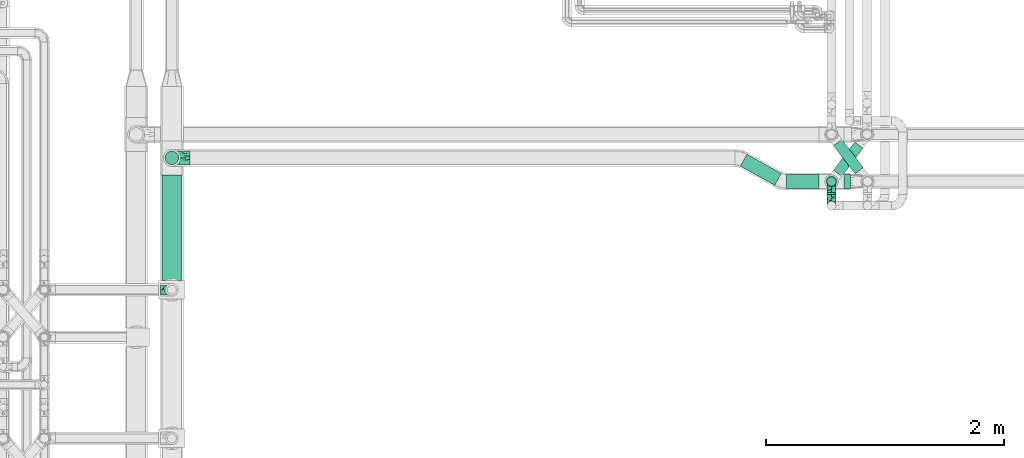
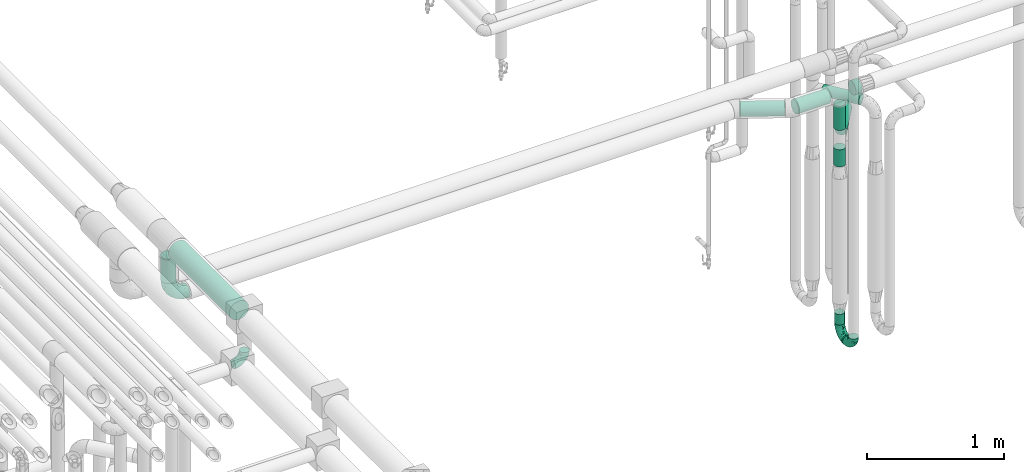
# One storey, part 628 of 827: 11 flow segments, 4 flow fittings.
"""IFC2X3 building model written with IfcOpenShell, lengths in millimetres."""

from ifc_helpers import new_model, entity, si_unit, converted_unit, derived_unit, direction, frame, origin, origin_2d_with_axis, place, context, subcontext, project, spatial, circle, extrude, faceted_brep, source, transform, mapped, material, type_object, type_shapes, element, save


model = new_model("IFC2X3")

# Units and contexts
model_context = context("Model", 3, precision=0.01, world=origin(), true_north=direction((6.12303176911189e-17, 1.0)))
body_context = subcontext(model_context, "Body", "Model", "MODEL_VIEW")
ifc_project = project(units=[si_unit("LENGTHUNIT", "METRE", prefix="MILLI"), si_unit("AREAUNIT", "SQUARE_METRE"), si_unit("VOLUMEUNIT", "CUBIC_METRE"), converted_unit("PLANEANGLEUNIT", "DEGREE", entity("IfcRatioMeasure", 0.0174532925199433), si_unit("PLANEANGLEUNIT", "RADIAN"), dimensions=[0, 0, 0, 0, 0, 0, 0]), si_unit("MASSUNIT", "GRAM", prefix="KILO"), derived_unit("MASSDENSITYUNIT", [(si_unit("MASSUNIT", "GRAM", prefix="KILO"), 1), (si_unit("LENGTHUNIT", "METRE"), -3)]), derived_unit("MOMENTOFINERTIAUNIT", [(si_unit("LENGTHUNIT", "METRE"), 4)]), si_unit("TIMEUNIT", "SECOND"), si_unit("FREQUENCYUNIT", "HERTZ"), si_unit("THERMODYNAMICTEMPERATUREUNIT", "DEGREE_CELSIUS"), derived_unit("THERMALTRANSMITTANCEUNIT", [(si_unit("MASSUNIT", "GRAM", prefix="KILO"), 1), (si_unit("THERMODYNAMICTEMPERATUREUNIT", "KELVIN"), -1), (si_unit("TIMEUNIT", "SECOND"), -3)]), derived_unit("VOLUMETRICFLOWRATEUNIT", [(si_unit("LENGTHUNIT", "METRE"), 3), (si_unit("TIMEUNIT", "SECOND"), -1)]), derived_unit("MASSFLOWRATEUNIT", [(si_unit("MASSUNIT", "GRAM", prefix="KILO"), 1), (si_unit("TIMEUNIT", "SECOND"), -1)]), derived_unit("ROTATIONALFREQUENCYUNIT", [(si_unit("TIMEUNIT", "SECOND"), -1)]), si_unit("ELECTRICCURRENTUNIT", "AMPERE"), si_unit("ELECTRICVOLTAGEUNIT", "VOLT"), si_unit("POWERUNIT", "WATT"), si_unit("FORCEUNIT", "NEWTON", prefix="KILO"), si_unit("ILLUMINANCEUNIT", "LUX"), si_unit("LUMINOUSFLUXUNIT", "LUMEN"), si_unit("LUMINOUSINTENSITYUNIT", "CANDELA"), derived_unit("USERDEFINED", [(si_unit("MASSUNIT", "GRAM", prefix="KILO"), -1), (si_unit("LENGTHUNIT", "METRE"), -2), (si_unit("TIMEUNIT", "SECOND"), 3), (si_unit("LUMINOUSFLUXUNIT", "LUMEN"), 1)]), derived_unit("LINEARVELOCITYUNIT", [(si_unit("LENGTHUNIT", "METRE"), 1), (si_unit("TIMEUNIT", "SECOND"), -1)]), si_unit("PRESSUREUNIT", "PASCAL"), derived_unit("USERDEFINED", [(si_unit("LENGTHUNIT", "METRE"), -2), (si_unit("MASSUNIT", "GRAM", prefix="KILO"), 1), (si_unit("TIMEUNIT", "SECOND"), -2)]), derived_unit("LINEARFORCEUNIT", [(si_unit("MASSUNIT", "GRAM", prefix="KILO"), 1), (si_unit("LENGTHUNIT", "METRE"), 1), (si_unit("TIMEUNIT", "SECOND"), -2), (si_unit("LENGTHUNIT", "METRE"), -1)]), derived_unit("PLANARFORCEUNIT", [(si_unit("MASSUNIT", "GRAM", prefix="KILO"), 1), (si_unit("LENGTHUNIT", "METRE"), 1), (si_unit("TIMEUNIT", "SECOND"), -2), (si_unit("LENGTHUNIT", "METRE"), -2)])], contexts=[model_context])

# Site, building, storey
site_placement = place(None, origin())
site = spatial("IfcSite", under=ifc_project, at=site_placement, CompositionType="ELEMENT")
building_placement = place(site_placement, origin())
building = spatial("IfcBuilding", under=site, at=building_placement, CompositionType="ELEMENT")
storey_placement = place(building_placement, frame((0.0, 0.0, 28200.0)))
storey = spatial("IfcBuildingStorey", under=building, at=storey_placement, Name="08", CompositionType="ELEMENT", Elevation=28200.0)

# Flow segments
pipe_segment_type = type_object("IfcPipeSegmentType", PredefinedType="NOTDEFINED")
flow_segment_1_placement = place(storey_placement, frame((43217.53, 13831.58, 2441.4)))
element("IfcFlowSegment", 1, at=flow_segment_1_placement, inside=storey, type_object=pipe_segment_type, context=body_context, shape_type="SweptSolid", body=[
    extrude(circle(Radius=57.0, at=origin_2d_with_axis()), frame((0.0, 58.6, 58.6), z_axis=(1.0, 0.0, 0.0), x_axis=(0.0, 1.0, 0.0)), (0.0, 0.0, 1.0), 272.991412851327),
])
flow_segment_2_placement = place(storey_placement, frame((42827.16, 13856.6, 2441.4)))
element("IfcFlowSegment", 2, at=flow_segment_2_placement, inside=storey, type_object=pipe_segment_type, context=body_context, shape_type="SweptSolid", body=[
    extrude(circle(Radius=57.0, at=origin_2d_with_axis()), frame((319.01, 51.37, 58.6), z_axis=(-0.873180609526805, 0.48739678204354, 0.0), x_axis=(0.48739678204354, 0.873180609526805, 0.0)), (0.0, 0.0, 1.0), 331.703383330537),
])
flow_segment_3_placement = place(storey_placement, frame((43556.18, 13781.84, 310.65)))
element("IfcFlowSegment", 3, at=flow_segment_3_placement, inside=storey, type_object=pipe_segment_type, context=body_context, shape_type="SweptSolid", body=[
    extrude(circle(Radius=37.75, at=origin_2d_with_axis()), frame((39.35, 0.0, 39.35), z_axis=(0.0, 1.0, 0.0), x_axis=(1.0, 0.0, 0.0)), (0.0, 0.0, 1.0), 13.3318534116117),
])
flow_segment_4_placement = place(storey_placement, frame((43556.18, 13850.83, 445.0)))
element("IfcFlowSegment", 4, at=flow_segment_4_placement, inside=storey, type_object=pipe_segment_type, context=body_context, shape_type="SweptSolid", body=[
    extrude(circle(Radius=37.75, at=origin_2d_with_axis()), frame((39.35, 39.35, 0.0)), (0.0, 0.0, 1.0), 96.0215360887079),
])
flow_segment_5_placement = place(storey_placement, frame((43610.35, 13930.63, 2054.15)))
element("IfcFlowSegment", 5, at=flow_segment_5_placement, inside=storey, type_object=pipe_segment_type, context=body_context, shape_type="SweptSolid", body=[
    extrude(circle(Radius=44.25, at=origin_2d_with_axis()), frame((36.93, 28.23, 45.85), z_axis=(0.601815023152052, 0.79863551004729, 0.0), x_axis=(-0.79863551004729, 0.601815023152052, 0.0)), (0.0, 0.0, 1.0), 296.864462003746),
])
flow_segment_6_placement = place(storey_placement, frame((43549.68, 13844.33, 1860.0)))
element("IfcFlowSegment", 6, at=flow_segment_6_placement, inside=storey, type_object=pipe_segment_type, context=body_context, shape_type="SweptSolid", body=[
    extrude(circle(Radius=44.25, at=origin_2d_with_axis()), frame((45.85, 45.85, 0.0)), (0.0, 0.0, 1.0), 154.00000000003),
])
flow_segment_7_placement = place(storey_placement, frame((43549.68, 13844.33, 2186.0)))
element("IfcFlowSegment", 7, at=flow_segment_7_placement, inside=storey, type_object=pipe_segment_type, context=body_context, shape_type="SweptSolid", body=[
    extrude(circle(Radius=44.25, at=origin_2d_with_axis()), frame((45.85, 45.85, 0.0), z_axis=(0.0, 0.0, 1.0), x_axis=(-1.0, 0.0, 0.0)), (0.0, 0.0, 1.0), 215.999999999986),
])
flow_segment_8_placement = place(storey_placement, frame((43610.53, 13952.25, 2254.15)))
element("IfcFlowSegment", 8, at=flow_segment_8_placement, inside=storey, type_object=pipe_segment_type, context=body_context, shape_type="SweptSolid", body=[
    extrude(circle(Radius=44.25, at=origin_2d_with_axis()), frame((36.74, 266.05, 45.85), z_axis=(0.607471228521982, -0.794341681216587, 0.0), x_axis=(0.794341681216587, 0.607471228521982, 0.0)), (0.0, 0.0, 1.0), 299.088593690858),
])
flow_segment_9_placement = place(storey_placement, frame((37964.2, 13057.14, 2915.9)))
element("IfcFlowSegment", 9, at=flow_segment_9_placement, inside=storey, type_object=pipe_segment_type, context=body_context, shape_type="SweptSolid", body=[
    extrude(circle(Radius=82.5, at=origin_2d_with_axis()), frame((84.1, 0.0, 84.1), z_axis=(0.0, 1.0, 0.0), x_axis=(-1.0, 0.0, 0.0)), (0.0, 0.0, 1.0), 888.770675700639),
])
flow_segment_10_placement = place(storey_placement, frame((37989.7, 14030.32, 2652.0)))
element("IfcFlowSegment", 10, at=flow_segment_10_placement, inside=storey, type_object=pipe_segment_type, context=body_context, shape_type="SweptSolid", body=[
    extrude(circle(Radius=57.0, at=origin_2d_with_axis()), frame((58.6, 58.6, 0.0)), (0.0, 0.0, 1.0), 218.000000000007),
])
flow_segment_11_placement = place(storey_placement, frame((43700.53, 13831.58, 2441.4)))
element("IfcFlowSegment", 11, at=flow_segment_11_placement, inside=storey, type_object=pipe_segment_type, context=body_context, shape_type="SweptSolid", body=[
    extrude(circle(Radius=57.0, at=origin_2d_with_axis()), frame((0.0, 58.6, 58.6), z_axis=(1.0, 0.0, 0.0), x_axis=(0.0, 1.0, 0.0)), (0.0, 0.0, 1.0), 53.6562870233953),
])

# Flow fittings
ifc_material = material()
pipe_fitting_type_1 = type_object("IfcPipeFittingType", Name="ADSK_1", PredefinedType="NOTDEFINED", material=ifc_material)
shared_shape_1 = source(origin(), body_context, "Body", "Brep", [
    faceted_brep([(-95.0, 19.02, -32.95), (-95.0, 9.85, -36.75), (-95.0, 0.0, -38.05), (-95.0, -9.85, -36.75), (-95.0, -19.03, -32.95), (-95.0, -26.91, -26.91), (-95.0, -32.95, -19.03), (-95.0, -36.75, -9.85), (-95.0, -38.05, 0.0), (-95.0, -36.75, 9.85), (-95.0, -32.95, 19.02), (-95.0, -26.91, 26.91), (-95.0, -19.03, 32.95), (-95.0, -9.85, 36.75), (-95.0, 0.0, 38.05), (-95.0, 9.85, 36.75), (-95.0, 19.02, 32.95), (-95.0, 26.91, 26.91), (-95.0, 32.95, 19.02), (-95.0, 36.75, 9.85), (-95.0, 38.05, 0.0), (-95.0, 36.75, -9.85), (-95.0, 32.95, -19.03), (-95.0, 26.91, -26.91), (0.0, 95.0, -38.05), (-9.85, 95.0, -36.75), (-19.02, 95.0, -32.95), (-26.91, 95.0, -26.91), (-32.95, 95.0, -19.03), (-36.75, 95.0, -9.85), (-38.05, 95.0, 0.0), (-36.75, 95.0, 9.85), (-32.95, 95.0, 19.02), (-26.91, 95.0, 26.91), (-19.02, 95.0, 32.95), (-9.85, 95.0, 36.75), (0.0, 95.0, 38.05), (9.85, 95.0, 36.75), (19.03, 95.0, 32.95), (26.91, 95.0, 26.91), (32.95, 95.0, 19.02), (36.75, 95.0, 9.85), (38.05, 95.0, 0.0), (36.75, 95.0, -9.85), (32.95, 95.0, -19.03), (26.91, 95.0, -26.91), (19.03, 95.0, -32.95), (9.85, 95.0, -36.75), (-7.99, -4.96, 6.3), (-0.92, 0.92, 0.0), (4.62, 8.1, 8.01), (-76.19, -35.57, 0.0), (-64.32, -32.32, 12.43), (20.51, 62.45, 28.68), (-60.56, -33.52, 0.0), (-70.4, -13.47, 34.42), (-39.61, -5.88, 32.32), (-49.6, 2.07, 37.1), (-70.34, -28.81, 21.71), (14.64, 40.81, 26.5), (5.88, 39.61, 32.32), (3.59, 20.77, 25.31), (-40.45, 68.06, 16.75), (-62.45, -20.51, 28.68), (-44.52, -26.87, 0.0), (-28.47, -20.22, 0.0), (-26.43, -17.83, 8.75), (-76.1, 39.63, 10.76), (-72.74, 37.58, 18.19), (-60.35, 46.18, 14.61), (-13.4, 13.4, 32.12), (-20.77, -3.59, 25.31), (-14.66, 81.47, 35.56), (-6.22, 71.26, 37.92), (-57.5, 42.48, 22.79), (-15.0, 34.74, 37.7), (-27.1, 12.08, 36.05), (-9.2, 28.81, 35.63), (-79.98, 23.7, 30.95), (-73.68, -4.3, 37.48), (-30.74, 21.67, 37.97), (-62.36, 47.59, 6.79), (-72.71, 32.83, 24.69), (-67.42, 7.02, 37.95), (-32.13, 75.27, 24.51), (-43.46, 51.47, 26.26), (-24.98, 73.15, 31.29), (20.59, 41.28, 19.85), (7.79, 16.09, 15.86), (-73.21, 42.39, 0.0), (-54.73, 54.73, 0.0), (-73.44, 15.79, 35.79), (-5.94, 4.32, 20.43), (28.81, 70.34, 21.71), (32.32, 64.32, 12.43), (-53.59, 26.2, 35.09), (-52.02, 19.31, 37.21), (21.38, 33.53, 10.34), (26.87, 44.52, 0.0), (-48.28, 12.14, 38.05), (4.3, 73.68, 37.48), (-44.08, -25.52, 12.79), (-41.28, -20.59, 19.85), (35.57, 76.19, 0.0), (-47.26, 54.3, 20.18), (-47.4, 61.99, 8.58), (-42.39, 73.21, 0.0), (-39.67, 78.86, 7.21), (-45.69, 36.84, 33.11), (-32.83, 50.13, 33.35), (13.47, 70.4, 34.42), (-18.25, 63.73, 36.07), (-40.63, -13.75, 27.22), (-16.63, 46.37, 37.95), (-53.47, 38.79, 28.59), (-26.07, 48.54, 36.15), (-34.51, 34.51, 36.86), (-2.07, 49.6, 37.1), (-22.79, -10.49, 19.23), (-61.73, 28.67, 31.87), (9.65, 14.7, 0.0), (20.22, 28.47, 0.0), (33.52, 60.56, 0.0), (-11.42, -5.44, 13.25), (-14.7, -9.65, 0.0), (-81.47, 14.66, -35.56), (-62.45, -20.51, -28.68), (-71.26, 6.22, -37.92), (-75.27, 32.13, -24.51), (-73.15, 24.98, -31.29), (13.47, 70.4, -34.42), (5.88, 39.61, -32.32), (-2.07, 49.6, -37.1), (-78.86, 39.67, -7.21), (-70.4, -13.47, -34.42), (-39.61, -5.88, -32.32), (-61.99, 47.4, -8.58), (32.32, 64.32, -12.43), (28.81, 70.34, -21.71), (-63.73, 18.25, -36.07), (-50.13, 32.83, -33.35), (4.3, 73.68, -37.48), (-7.02, 67.42, -37.95), (-39.63, 76.1, -10.76), (-46.18, 60.35, -14.61), (-47.59, 62.36, -6.79), (-64.32, -32.32, -12.43), (-26.2, 53.59, -35.09), (-15.79, 73.44, -35.79), (-19.31, 52.02, -37.21), (-37.58, 72.74, -18.19), (-70.34, -28.81, -21.71), (-42.48, 57.5, -22.79), (-38.79, 53.47, -28.59), (-51.47, 43.46, -26.26), (-32.83, 72.71, -24.69), (-46.37, 16.63, -37.95), (-73.68, -4.3, -37.48), (-41.28, -20.59, -19.85), (-44.08, -25.52, -12.79), (13.75, 40.63, -27.22), (20.51, 62.45, -28.68), (-68.06, 40.45, -16.75), (-54.3, 47.26, -20.18), (-12.14, 48.28, -38.05), (-21.67, 30.74, -37.97), (-36.84, 45.69, -33.11), (-11.42, -5.44, -13.25), (7.79, 16.09, -15.86), (4.62, 8.1, -8.01), (-23.7, 79.98, -30.95), (-26.43, -17.83, -8.75), (-7.99, -4.96, -6.3), (-40.81, -14.64, -26.5), (-20.77, -3.59, -25.31), (-34.74, 15.0, -37.7), (-12.08, 27.1, -36.05), (-28.81, 9.2, -35.63), (-22.79, -10.49, -19.23), (21.38, 33.53, -10.34), (20.59, 41.28, -19.85), (-48.54, 26.07, -36.15), (-49.6, 2.07, -37.1), (-13.4, 13.4, -32.12), (3.59, 20.77, -25.31), (-28.67, 61.73, -31.87), (-34.51, 34.51, -36.86), (-5.94, 4.32, -20.43)], [[[0, 1, 2, 3, 4, 5, 6, 7, 8, 9, 10, 11, 12, 13, 14, 15, 16, 17, 18, 19, 20, 21, 22, 23]], [[24, 25, 26, 27, 28, 29, 30, 31, 32, 33, 34, 35, 36, 37, 38, 39, 40, 41, 42, 43, 44, 45, 46, 47]], [[48, 49, 50]], [[51, 52, 9]], [[53, 39, 38]], [[9, 52, 10]], [[54, 52, 51]], [[55, 56, 57]], [[11, 10, 58]], [[59, 60, 61]], [[32, 31, 62]], [[63, 12, 11]], [[63, 55, 12]], [[64, 65, 66]], [[67, 68, 69]], [[70, 56, 71]], [[35, 72, 73]], [[69, 68, 74]], [[75, 76, 77]], [[16, 78, 17]], [[13, 79, 14]], [[76, 75, 80]], [[67, 69, 81]], [[18, 17, 82]], [[14, 79, 83]], [[20, 19, 67]], [[84, 85, 86]], [[87, 61, 88]], [[89, 81, 90]], [[18, 82, 68]], [[15, 91, 16]], [[14, 83, 15]], [[71, 92, 61]], [[17, 78, 82]], [[93, 87, 94]], [[95, 91, 96]], [[97, 98, 94]], [[86, 72, 34]], [[96, 99, 80]], [[37, 36, 100]], [[40, 39, 93]], [[40, 94, 41]], [[64, 66, 101]], [[93, 94, 40]], [[58, 102, 63]], [[94, 103, 41]], [[94, 87, 97]], [[104, 69, 74]], [[34, 33, 86]], [[105, 69, 104]], [[52, 58, 10]], [[106, 107, 30]], [[108, 109, 85]], [[105, 106, 90]], [[53, 110, 60]], [[86, 111, 72]], [[86, 109, 111]], [[33, 84, 86]], [[12, 55, 13]], [[112, 56, 63]], [[110, 38, 37]], [[34, 72, 35]], [[36, 35, 73]], [[111, 113, 73]], [[105, 107, 106]], [[110, 53, 38]], [[74, 114, 85]], [[91, 15, 83]], [[105, 90, 81]], [[107, 62, 31]], [[33, 32, 84]], [[115, 109, 116]], [[111, 115, 113]], [[100, 73, 117]], [[56, 55, 63]], [[79, 55, 57]], [[102, 118, 112]], [[56, 70, 76]], [[100, 110, 37]], [[117, 77, 60]], [[117, 60, 110]], [[60, 70, 61]], [[58, 52, 101]], [[63, 11, 58]], [[39, 53, 93]], [[87, 93, 53]], [[96, 91, 83]], [[78, 91, 119]], [[32, 62, 84]], [[84, 62, 104]], [[86, 85, 109]], [[85, 114, 108]], [[80, 113, 116]], [[117, 73, 113]], [[80, 116, 96]], [[80, 57, 76]], [[71, 112, 118]], [[61, 87, 59]], [[62, 107, 105]], [[97, 120, 121]], [[70, 71, 61]], [[71, 118, 92]], [[73, 100, 36]], [[110, 100, 117]], [[55, 79, 13]], [[83, 79, 57]], [[96, 83, 99]], [[116, 108, 95]], [[50, 97, 88]], [[97, 87, 88]], [[50, 49, 120]], [[122, 94, 98]], [[89, 20, 67]], [[105, 81, 69]], [[89, 67, 81]], [[68, 19, 18]], [[68, 67, 19]], [[74, 68, 82]], [[114, 82, 119]], [[74, 85, 104]], [[82, 114, 74]], [[114, 119, 108]], [[95, 108, 119]], [[116, 109, 108]], [[123, 48, 50]], [[97, 50, 120]], [[123, 50, 88]], [[91, 95, 119]], [[116, 95, 96]], [[84, 104, 85]], [[104, 62, 105]], [[83, 57, 99]], [[57, 80, 99]], [[66, 48, 123]], [[66, 124, 48]], [[118, 66, 123]], [[124, 66, 65]], [[66, 118, 101]], [[54, 64, 52]], [[124, 49, 48]], [[30, 107, 31]], [[91, 78, 16]], [[82, 78, 119]], [[56, 76, 57]], [[77, 76, 70]], [[60, 77, 70]], [[77, 117, 75]], [[117, 113, 75]], [[113, 80, 75]], [[9, 8, 51]], [[103, 94, 122]], [[103, 42, 41]], [[73, 72, 111]], [[113, 115, 116]], [[111, 109, 115]], [[102, 112, 63]], [[71, 56, 112]], [[118, 102, 101]], [[92, 123, 88]], [[123, 92, 118]], [[61, 92, 88]], [[87, 53, 59]], [[60, 59, 53]], [[97, 121, 98]], [[58, 101, 102]], [[64, 101, 52]], [[125, 1, 0]], [[126, 5, 4]], [[2, 1, 127]], [[1, 125, 127]], [[128, 129, 23]], [[130, 131, 132]], [[89, 133, 20]], [[126, 134, 135]], [[136, 89, 90]], [[137, 138, 44]], [[139, 129, 140]], [[24, 141, 142]], [[143, 144, 145]], [[125, 129, 139]], [[6, 146, 7]], [[147, 148, 149]], [[146, 51, 7]], [[143, 150, 144]], [[146, 6, 151]], [[152, 153, 154]], [[126, 4, 134]], [[0, 23, 129]], [[28, 155, 150]], [[43, 42, 103]], [[54, 146, 64]], [[139, 156, 127]], [[157, 3, 2]], [[151, 158, 159]], [[160, 131, 161]], [[22, 21, 162]], [[136, 144, 163]], [[149, 164, 165]], [[24, 142, 25]], [[166, 140, 154]], [[154, 129, 128]], [[143, 30, 29]], [[167, 168, 169]], [[155, 28, 27]], [[26, 170, 27]], [[171, 167, 172]], [[26, 25, 148]], [[27, 170, 155]], [[173, 135, 174]], [[144, 150, 152]], [[175, 176, 177]], [[24, 47, 141]], [[45, 161, 46]], [[148, 25, 142]], [[176, 175, 165]], [[64, 159, 171]], [[138, 45, 44]], [[130, 46, 161]], [[137, 44, 43]], [[178, 159, 158]], [[137, 103, 122]], [[163, 144, 152]], [[136, 133, 89]], [[103, 137, 43]], [[6, 5, 151]], [[178, 158, 173]], [[134, 4, 3]], [[178, 173, 174]], [[137, 98, 179]], [[145, 90, 106]], [[138, 180, 161]], [[46, 130, 47]], [[136, 90, 145]], [[133, 162, 21]], [[23, 22, 128]], [[139, 140, 181]], [[139, 181, 156]], [[157, 127, 182]], [[157, 134, 3]], [[182, 177, 135]], [[182, 135, 134]], [[135, 183, 174]], [[131, 130, 161]], [[141, 130, 132]], [[160, 180, 184]], [[131, 183, 176]], [[5, 126, 151]], [[158, 151, 126]], [[180, 138, 137]], [[161, 45, 138]], [[149, 148, 142]], [[170, 148, 185]], [[22, 162, 128]], [[128, 162, 163]], [[129, 154, 140]], [[154, 153, 166]], [[165, 156, 186]], [[182, 127, 156]], [[165, 186, 149]], [[165, 132, 176]], [[131, 184, 183]], [[187, 167, 178]], [[184, 168, 187]], [[167, 169, 172]], [[184, 180, 168]], [[174, 183, 184]], [[127, 157, 2]], [[134, 157, 182]], [[130, 141, 47]], [[142, 141, 132]], [[149, 142, 164]], [[186, 166, 147]], [[180, 179, 168]], [[169, 179, 120]], [[137, 179, 180]], [[179, 121, 120]], [[106, 30, 143]], [[136, 145, 144]], [[106, 143, 145]], [[150, 29, 28]], [[150, 143, 29]], [[152, 150, 155]], [[153, 155, 185]], [[152, 154, 163]], [[155, 153, 152]], [[153, 185, 166]], [[147, 166, 185]], [[186, 140, 166]], [[169, 120, 49]], [[169, 49, 172]], [[179, 169, 168]], [[148, 147, 185]], [[186, 147, 149]], [[128, 163, 154]], [[163, 162, 136]], [[142, 132, 164]], [[132, 165, 164]], [[171, 124, 65]], [[124, 171, 172]], [[64, 146, 159]], [[171, 159, 178]], [[171, 65, 64]], [[172, 49, 124]], [[162, 133, 136]], [[20, 133, 21]], [[148, 170, 26]], [[155, 170, 185]], [[131, 176, 132]], [[177, 176, 183]], [[135, 177, 183]], [[177, 182, 175]], [[182, 156, 175]], [[156, 165, 175]], [[51, 146, 54]], [[51, 8, 7]], [[129, 125, 0]], [[127, 125, 139]], [[140, 186, 181]], [[156, 181, 186]], [[158, 126, 173]], [[135, 173, 126]], [[187, 178, 174]], [[171, 178, 167]], [[184, 187, 174]], [[167, 187, 168]], [[180, 160, 161]], [[184, 131, 160]], [[98, 137, 122]], [[98, 121, 179]], [[151, 159, 146]]]),
])
type_shapes(pipe_fitting_type_1, [shared_shape_1])
for number, where, z_axis, x_axis, name in (
    (12, (43595.53, 13686.84, 350.0), (1.0, 0.0, 0.0), (0.0, 0.0, -1.0), "ADSK_1"),
    (13, (43595.53, 13890.17, 350.0), (1.0, 0.0, 0.0), (0.0, 1.0, 0.0), "ADSK_1"),
    (14, (38048.3, 12979.64, 2600.0), (0.0, 1.0, 0.0), (0.0, 0.0, -1.0), "ADSK_1"),
):
    element("IfcFlowFitting", number, at=place(storey_placement, frame(where, z_axis=z_axis, x_axis=x_axis)), inside=storey, type_object=pipe_fitting_type_1, material=ifc_material, Name=name, ObjectType="ADSK_1", context=body_context, shape_type="MappedRepresentation", body=[
        mapped(shared_shape_1, transform((0.0, 0.0, 0.0), scale=1.0)),
    ])
pipe_fitting_type_2 = type_object("IfcPipeFittingType", Name="ADSK_1", PredefinedType="NOTDEFINED", material=ifc_material)
shared_shape_2 = source(origin(), body_context, "Body", "Brep", [
    faceted_brep([(-152.0, 28.57, -49.49), (-152.0, 14.79, -55.2), (-152.0, 0.0, -57.15), (-152.0, -14.79, -55.2), (-152.0, -28.58, -49.49), (-152.0, -40.41, -40.41), (-152.0, -49.49, -28.58), (-152.0, -55.2, -14.79), (-152.0, -57.15, 0.0), (-152.0, -55.2, 14.79), (-152.0, -49.49, 28.57), (-152.0, -40.41, 40.41), (-152.0, -28.58, 49.49), (-152.0, -14.79, 55.2), (-152.0, 0.0, 57.15), (-152.0, 14.79, 55.2), (-152.0, 28.57, 49.49), (-152.0, 40.41, 40.41), (-152.0, 49.49, 28.57), (-152.0, 55.2, 14.79), (-152.0, 57.15, 0.0), (-152.0, 55.2, -14.79), (-152.0, 49.49, -28.58), (-152.0, 40.41, -40.41), (0.0, 152.0, -57.15), (-14.79, 152.0, -55.2), (-28.57, 152.0, -49.49), (-40.41, 152.0, -40.41), (-49.49, 152.0, -28.58), (-55.2, 152.0, -14.79), (-57.15, 152.0, 0.0), (-55.2, 152.0, 14.79), (-49.49, 152.0, 28.57), (-40.41, 152.0, 40.41), (-28.57, 152.0, 49.49), (-14.79, 152.0, 55.2), (0.0, 152.0, 57.15), (14.79, 152.0, 55.2), (28.58, 152.0, 49.49), (40.41, 152.0, 40.41), (49.49, 152.0, 28.57), (55.2, 152.0, 14.79), (57.15, 152.0, 0.0), (55.2, 152.0, -14.79), (49.49, 152.0, -28.58), (40.41, 152.0, -40.41), (28.58, 152.0, -49.49), (14.79, 152.0, -55.2), (20.7, 66.24, 39.99), (7.34, 64.45, 48.76), (2.83, 34.81, 38.56), (-101.45, -47.69, 18.75), (-105.46, -51.91, 0.0), (-112.89, -19.82, 51.77), (-64.45, -7.34, 48.76), (-80.19, 4.2, 55.81), (-21.6, -11.52, 0.0), (-43.75, -24.56, 15.16), (-61.25, -36.44, 0.0), (-112.43, -42.87, 32.73), (-108.19, 11.06, 56.98), (-76.43, 19.55, 57.15), (-83.73, 30.06, 55.82), (-4.77, 4.77, 10.34), (24.56, 43.75, 15.16), (-7.63, 7.63, 23.32), (-71.33, -36.99, 20.14), (-79.31, -43.21, 9.8), (-100.13, -30.16, 43.21), (-34.81, -2.83, 38.56), (-23.25, 23.25, 48.6), (-118.29, -6.15, 56.32), (-95.0, 35.3, 52.69), (-117.56, 24.09, 53.71), (30.16, 100.13, 43.21), (-30.8, 82.44, 55.82), (-19.58, 77.94, 57.15), (-11.06, 108.19, 56.98), (-55.14, 127.37, 23.59), (-66.52, 104.72, 17.78), (-20.71, 44.99, 54.44), (-34.99, 50.26, 57.07), (-50.81, 24.59, 56.14), (-61.79, 122.69, 0.0), (-127.37, 55.14, 23.59), (-104.72, 66.52, 17.78), (-122.69, 61.79, 0.0), (-62.6, 101.6, 28.78), (-82.08, 82.08, 21.09), (-78.25, 78.25, 31.48), (-115.85, 49.79, 36.97), (-127.38, 35.89, 46.44), (-96.25, 75.26, 0.0), (19.82, 112.89, 51.77), (6.15, 118.29, 56.32), (-24.09, 117.56, 53.71), (51.91, 105.46, 0.0), (47.69, 101.45, 18.75), (39.92, 72.08, 11.93), (29.32, 66.24, 30.1), (-4.2, 80.19, 55.81), (-66.24, -29.32, 30.1), (42.87, 112.43, 32.73), (-84.3, 84.3, 10.02), (-75.26, 96.25, 0.0), (11.52, 21.6, 0.0), (-49.88, 115.55, 36.98), (-35.33, -13.95, 26.07), (-35.97, 126.84, 46.46), (-44.66, 96.87, 47.79), (-97.78, 44.27, 47.75), (-68.1, 60.31, 49.98), (-80.79, 64.17, 41.84), (-61.05, 78.49, 45.14), (-61.89, 90.36, 37.84), (-65.92, -19.11, 41.26), (36.44, 61.25, 0.0), (-101.6, 62.6, 28.78), (-56.0, 8.36, 53.24), (-46.59, 76.66, 52.56), (-55.91, 53.97, 55.22), (13.95, 35.33, 26.07), (-126.84, 35.97, -46.46), (-100.13, -30.16, -43.21), (-80.19, 4.2, -55.81), (-118.29, -6.15, -56.32), (-108.19, 11.06, -56.98), (-101.6, 62.6, -28.78), (-127.37, 55.14, -23.59), (-104.72, 66.52, -17.78), (-117.56, 24.09, -53.71), (-82.44, 30.8, -55.82), (-49.79, 115.85, -36.97), (47.69, 101.45, -18.75), (42.87, 112.43, -32.73), (-84.3, 84.3, -10.02), (-55.14, 127.37, -23.59), (-96.87, 44.66, -47.79), (-115.55, 49.88, -36.98), (-101.45, -47.69, -18.75), (-50.26, 34.99, -57.07), (-77.94, 19.58, -57.15), (-30.06, 83.73, -55.82), (-35.3, 95.0, -52.69), (-24.09, 117.56, -53.71), (-112.43, -42.87, -32.73), (-11.06, 108.19, -56.98), (-19.55, 76.43, -57.15), (-43.75, -24.56, -15.16), (-7.63, 7.63, -23.32), (-4.77, 4.77, -10.34), (-72.08, -39.92, -11.93), (-64.17, 80.79, -41.84), (-78.49, 61.05, -45.14), (-90.36, 61.89, -37.84), (-66.24, -29.32, -30.1), (-34.81, -2.83, -38.56), (2.83, 34.81, -38.56), (-66.52, 104.72, -17.78), (-82.08, 82.08, -21.09), (29.32, 66.24, -30.1), (30.16, 100.13, -43.21), (19.82, 112.89, -51.77), (7.34, 64.45, -48.76), (-4.2, 80.19, -55.81), (-78.25, 78.25, -31.48), (24.56, 43.75, -15.16), (-35.89, 127.38, -46.44), (6.15, 118.29, -56.32), (-44.99, 20.71, -54.44), (-24.59, 50.81, -56.14), (-66.24, -20.7, -39.99), (-64.45, -7.34, -48.76), (-44.27, 97.78, -47.75), (-60.31, 68.1, -49.98), (43.21, 79.31, -9.8), (36.99, 71.33, -20.14), (-112.89, -19.82, -51.77), (19.11, 65.92, -41.26), (13.95, 35.33, -26.07), (-62.6, 101.6, -28.78), (-23.25, 23.25, -48.6), (-8.36, 56.0, -53.24), (-76.66, 46.59, -52.56), (-53.97, 55.91, -55.22), (-35.33, -13.95, -26.07)], [[[0, 1, 2, 3, 4, 5, 6, 7, 8, 9, 10, 11, 12, 13, 14, 15, 16, 17, 18, 19, 20, 21, 22, 23]], [[24, 25, 26, 27, 28, 29, 30, 31, 32, 33, 34, 35, 36, 37, 38, 39, 40, 41, 42, 43, 44, 45, 46, 47]], [[48, 49, 50]], [[51, 9, 52]], [[53, 54, 55]], [[9, 51, 10]], [[9, 8, 52]], [[56, 57, 58]], [[10, 59, 11]], [[60, 61, 62]], [[63, 64, 65]], [[66, 67, 57]], [[12, 11, 68]], [[54, 69, 70]], [[68, 53, 12]], [[14, 71, 60]], [[62, 72, 73]], [[74, 39, 38]], [[75, 76, 77]], [[73, 16, 15]], [[14, 60, 15]], [[78, 31, 79]], [[13, 71, 14]], [[80, 81, 82]], [[31, 83, 79]], [[19, 84, 85]], [[73, 15, 60]], [[86, 20, 19]], [[87, 88, 89]], [[90, 17, 91]], [[86, 85, 92]], [[86, 19, 85]], [[91, 17, 16]], [[87, 78, 79]], [[93, 74, 38]], [[77, 36, 35]], [[94, 37, 36]], [[35, 34, 95]], [[96, 97, 98]], [[96, 41, 97]], [[99, 64, 98]], [[100, 94, 77]], [[59, 101, 68]], [[40, 97, 41]], [[97, 102, 99]], [[97, 40, 102]], [[74, 93, 49]], [[93, 38, 37]], [[67, 52, 58]], [[42, 41, 96]], [[40, 39, 102]], [[12, 53, 13]], [[83, 31, 30]], [[103, 104, 92]], [[105, 63, 56]], [[51, 59, 10]], [[106, 33, 32]], [[79, 83, 104]], [[107, 101, 66]], [[77, 95, 75]], [[85, 88, 103]], [[108, 106, 109]], [[17, 90, 18]], [[110, 111, 112]], [[48, 50, 99]], [[108, 34, 33]], [[77, 35, 95]], [[112, 113, 114]], [[115, 54, 68]], [[64, 105, 116]], [[75, 81, 76]], [[84, 19, 18]], [[78, 32, 31]], [[114, 106, 87]], [[112, 90, 110]], [[117, 85, 84]], [[54, 53, 68]], [[71, 53, 55]], [[115, 101, 69]], [[118, 82, 55]], [[94, 93, 37]], [[100, 80, 49]], [[100, 49, 93]], [[49, 70, 50]], [[59, 51, 66]], [[68, 11, 59]], [[39, 74, 102]], [[99, 102, 74]], [[108, 95, 34]], [[75, 119, 120]], [[62, 73, 60]], [[73, 72, 91]], [[57, 56, 63]], [[57, 107, 66]], [[98, 64, 116]], [[121, 64, 99]], [[107, 69, 101]], [[65, 121, 50]], [[70, 69, 50]], [[65, 50, 69]], [[119, 95, 109]], [[75, 120, 81]], [[120, 62, 61]], [[81, 61, 82]], [[77, 94, 36]], [[93, 94, 100]], [[53, 71, 13]], [[60, 71, 55]], [[60, 55, 61]], [[120, 111, 72]], [[82, 61, 55]], [[120, 61, 81]], [[118, 55, 54]], [[81, 80, 100]], [[118, 80, 82]], [[49, 80, 70]], [[54, 70, 118]], [[80, 118, 70]], [[79, 88, 87]], [[106, 32, 78]], [[114, 87, 89]], [[106, 78, 87]], [[112, 114, 89]], [[109, 106, 114]], [[112, 89, 117]], [[111, 110, 72]], [[119, 111, 120]], [[114, 113, 109]], [[18, 90, 84]], [[117, 89, 88]], [[84, 90, 117]], [[112, 117, 90]], [[106, 108, 33]], [[95, 108, 109]], [[73, 91, 16]], [[90, 91, 110]], [[95, 119, 75]], [[119, 109, 113]], [[81, 100, 76]], [[100, 77, 76]], [[79, 104, 103]], [[117, 88, 85]], [[85, 103, 92]], [[79, 103, 88]], [[64, 63, 105]], [[57, 63, 65]], [[57, 65, 107]], [[69, 107, 65]], [[59, 66, 101]], [[67, 66, 51]], [[52, 67, 51]], [[57, 67, 58]], [[96, 98, 116]], [[99, 98, 97]], [[50, 121, 99]], [[65, 64, 121]], [[101, 115, 68]], [[69, 54, 115]], [[99, 74, 48]], [[49, 48, 74]], [[72, 62, 120]], [[91, 72, 110]], [[112, 111, 113]], [[119, 113, 111]], [[23, 122, 0]], [[123, 5, 4]], [[124, 125, 126]], [[127, 128, 129]], [[130, 131, 126]], [[126, 2, 1]], [[20, 86, 21]], [[27, 132, 28]], [[92, 129, 86]], [[133, 134, 44]], [[104, 135, 92]], [[128, 21, 129]], [[136, 29, 28]], [[137, 122, 138]], [[138, 23, 22]], [[1, 130, 126]], [[6, 139, 7]], [[131, 140, 141]], [[52, 8, 7]], [[142, 143, 144]], [[139, 6, 145]], [[146, 147, 142]], [[58, 148, 56]], [[149, 150, 148]], [[21, 86, 129]], [[139, 52, 7]], [[139, 151, 52]], [[152, 153, 154]], [[125, 3, 2]], [[139, 145, 155]], [[1, 0, 130]], [[156, 157, 149]], [[158, 159, 135]], [[134, 160, 161]], [[162, 163, 164]], [[24, 146, 25]], [[159, 165, 127]], [[29, 83, 30]], [[105, 166, 116]], [[158, 29, 136]], [[144, 26, 25]], [[27, 167, 132]], [[47, 168, 24]], [[169, 140, 170]], [[83, 29, 158]], [[167, 27, 26]], [[171, 172, 156]], [[146, 144, 25]], [[173, 174, 152]], [[46, 161, 162]], [[56, 150, 105]], [[161, 46, 45]], [[24, 168, 146]], [[175, 166, 176]], [[123, 4, 177]], [[131, 141, 126]], [[133, 44, 43]], [[46, 162, 47]], [[42, 96, 43]], [[123, 177, 172]], [[177, 4, 3]], [[133, 43, 96]], [[178, 163, 161]], [[134, 45, 44]], [[6, 5, 145]], [[160, 176, 179]], [[155, 148, 151]], [[158, 104, 83]], [[175, 96, 116]], [[155, 171, 156]], [[128, 22, 21]], [[154, 138, 127]], [[152, 132, 173]], [[180, 158, 136]], [[125, 177, 3]], [[124, 169, 172]], [[124, 172, 177]], [[172, 181, 156]], [[163, 162, 161]], [[168, 162, 164]], [[178, 160, 157]], [[182, 170, 164]], [[5, 123, 145]], [[155, 145, 123]], [[134, 133, 176]], [[161, 45, 134]], [[122, 130, 0]], [[131, 183, 184]], [[142, 144, 146]], [[144, 143, 167]], [[151, 148, 58]], [[185, 148, 155]], [[166, 105, 150]], [[166, 179, 176]], [[157, 181, 163]], [[185, 156, 149]], [[157, 160, 179]], [[156, 181, 157]], [[183, 130, 137]], [[131, 184, 140]], [[184, 142, 147]], [[140, 147, 170]], [[126, 125, 2]], [[177, 125, 124]], [[162, 168, 47]], [[146, 168, 164]], [[146, 164, 147]], [[184, 174, 143]], [[170, 147, 164]], [[184, 147, 140]], [[182, 164, 163]], [[140, 169, 124]], [[182, 169, 170]], [[172, 169, 181]], [[163, 181, 182]], [[169, 182, 181]], [[129, 159, 127]], [[138, 22, 128]], [[154, 127, 165]], [[138, 128, 127]], [[152, 154, 165]], [[137, 138, 154]], [[152, 165, 180]], [[174, 173, 143]], [[183, 174, 184]], [[154, 153, 137]], [[28, 132, 136]], [[180, 165, 159]], [[136, 132, 180]], [[152, 180, 132]], [[138, 122, 23]], [[130, 122, 137]], [[144, 167, 26]], [[132, 167, 173]], [[130, 183, 131]], [[183, 137, 153]], [[140, 124, 141]], [[124, 126, 141]], [[129, 92, 135]], [[180, 159, 158]], [[158, 135, 104]], [[129, 135, 159]], [[148, 150, 56]], [[166, 150, 149]], [[52, 151, 58]], [[155, 151, 139]], [[156, 185, 155]], [[149, 148, 185]], [[166, 149, 179]], [[157, 179, 149]], [[134, 176, 160]], [[175, 176, 133]], [[96, 175, 133]], [[166, 175, 116]], [[155, 123, 171]], [[172, 171, 123]], [[160, 178, 161]], [[157, 163, 178]], [[143, 142, 184]], [[167, 143, 173]], [[152, 174, 153]], [[183, 153, 174]]]),
])
type_shapes(pipe_fitting_type_2, [shared_shape_2])
flow_fitting_placement = place(storey_placement, frame((38048.3, 14088.91, 2500.0), z_axis=(0.0, -1.0, 0.0), x_axis=(0.0, 0.0, -1.0)))
element("IfcFlowFitting", 15, at=flow_fitting_placement, inside=storey, type_object=pipe_fitting_type_2, material=ifc_material, Name="ADSK_1", ObjectType="ADSK_1", context=body_context, shape_type="MappedRepresentation", body=[
    mapped(shared_shape_2, transform((0.0, 0.0, 0.0), scale=1.0)),
])

save(model, "model.ifc")
